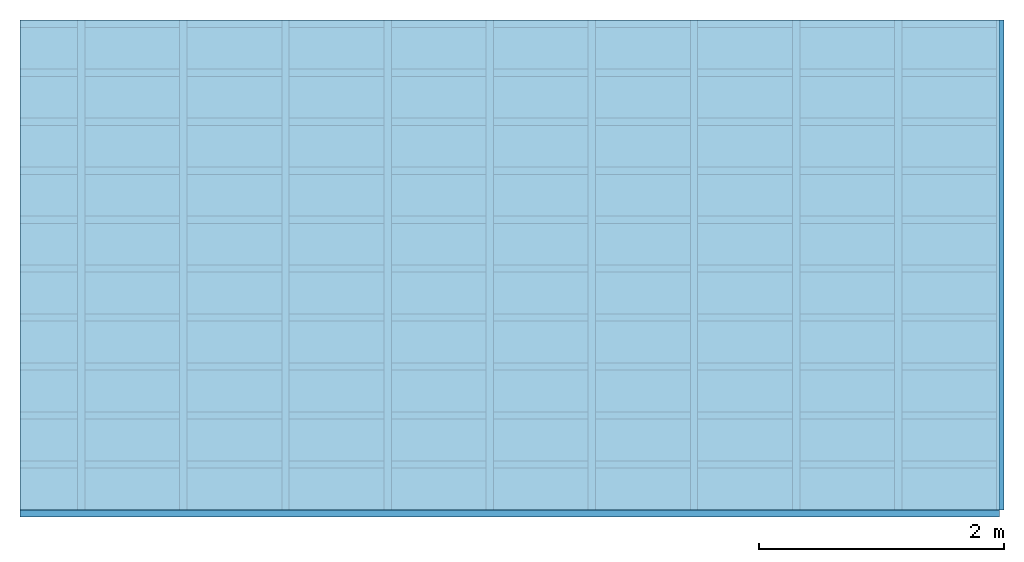
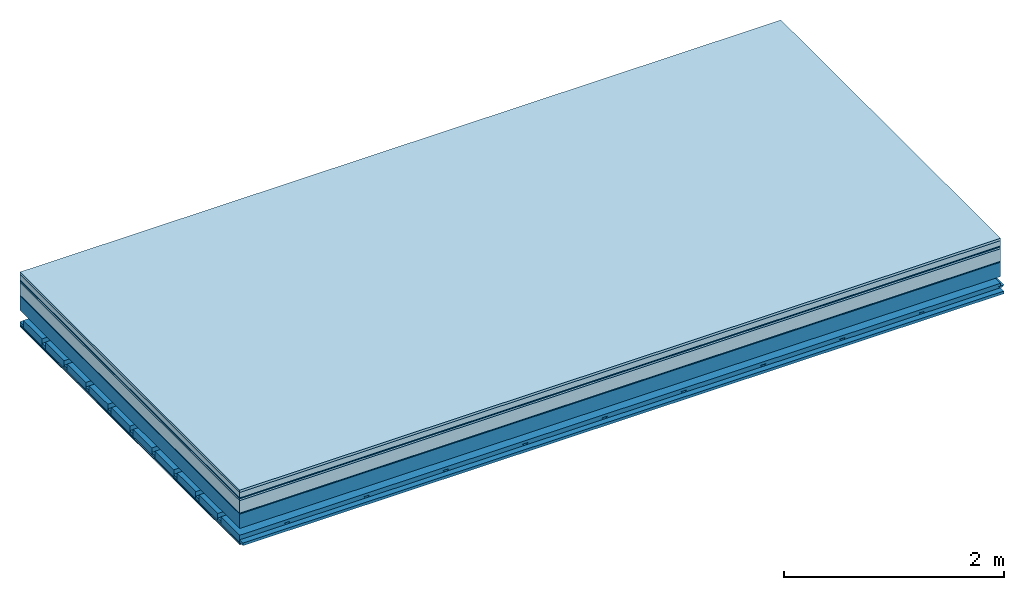
# One storey: 9 plates, 4 members, 1 element without a shape of its own.
"""IFC4 building model written with IfcOpenShell, lengths in metres."""

from ifc_helpers import new_model, si_unit, derived_unit, direction, frame, frame_2d, origin, origin_with_axes, place, context, project, spatial, polyline, rectangle, outline, extrude, material, layer, layer_set, type_object, element, aggregate, save


model = new_model("IFC4")

# Units and contexts
plan_context = context("Plan", 3, precision=1e-05, world=origin(), true_north=direction((0.0, 1.0)))
model_context = context("Model", 3, precision=1e-05, world=origin(), true_north=direction((0.0, 1.0)))
ifc_project = project(units=[si_unit("LENGTHUNIT", "METRE"), derived_unit("SOUNDPRESSUREUNIT", [(si_unit("PRESSUREUNIT", "PASCAL", prefix="MICRO"), 0)]), si_unit("ENERGYUNIT", "JOULE", prefix="MEGA"), si_unit("MASSUNIT", "GRAM", prefix="KILO"), derived_unit("THERMALTRANSMITTANCEUNIT", [(si_unit("POWERUNIT", "WATT"), 1), (si_unit("AREAUNIT", "SQUARE_METRE"), -1), (si_unit("THERMODYNAMICTEMPERATUREUNIT", "KELVIN"), -1)]), derived_unit("AREADENSITYUNIT", [(si_unit("MASSUNIT", "GRAM", prefix="KILO"), 1), (si_unit("AREAUNIT", "SQUARE_METRE"), -1)]), derived_unit("USERDEFINED", [(si_unit("ENERGYUNIT", "JOULE", prefix="MEGA"), 1), (si_unit("AREAUNIT", "SQUARE_METRE"), -1)])], contexts=[plan_context, model_context])

# Site, building, storey
site = spatial("IfcSite", under=ifc_project)
building_placement = place(None, origin())
building = spatial("IfcBuilding", under=site, at=building_placement)
storey_placement = place(building_placement, origin())
storey = spatial("IfcBuildingStorey", under=building, at=storey_placement)

# Slab, members, plates
ifc_material_1 = material(Category="07.009")
ifc_layer_1 = layer(ifc_material_1, 0.026, Name="Use and protection layer 3")
ifc_material_2 = material(Category="07.011")
ifc_layer_2 = layer(ifc_material_2, 0.06, Name="Use and protection layer 2")
ifc_material_3 = material(Name="Protective layer + Fire protection cover RF1", Category="09.007")
ifc_layer_3 = layer(ifc_material_3, 0.01, Name="Use and protection layer 1")
ifc_material_4 = material(Name="Bituminous", Category="09.003")
ifc_layer_4 = layer(ifc_material_4, 0.02, Name="Seal")
ifc_material_5 = material(Name="Mineral wool", Category="10.008")
ifc_layer_5 = layer(ifc_material_5, 0.14, Name="Exterior insulation layer 1")
ifc_material_6 = material(Name="Vapor-permeable barrier", Category="09.006")
ifc_layer_6 = layer(ifc_material_6, 0.01, Name="layer / temporary roof")
ifc_material_7 = material(Name="no composite action")
ifc_layer_7 = layer(ifc_material_7, 0.0, Name="Bond")
ifc_layer_8 = layer(None, 0.16, Name="Support")
ifc_layer_9 = layer(ifc_material_7, 0.0, Name="Bond")
ifc_layer_10 = layer(None, 0.125, Name="Coupling")
ifc_layer_11 = layer(None, 0.03, Name="Battens / profiles")
ifc_material_8 = material(Name="Plasterboard type A", Category="03.008")
ifc_layer_12 = layer(ifc_material_8, 0.0125, Name="Covering below 1st layer")
ifc_layer_13 = layer(ifc_material_8, 0.0125, Name="Covering below 2nd layer")
ifc_material_9 = material(Category="04.001")
ifc_layer_14 = layer(ifc_material_9, 0.003, Name="Surface below")
ifc_layer_set = layer_set([ifc_layer_1, ifc_layer_2, ifc_layer_3, ifc_layer_4, ifc_layer_5, ifc_layer_6, ifc_layer_7, ifc_layer_8, ifc_layer_9, ifc_layer_10, ifc_layer_11, ifc_layer_12, ifc_layer_13, ifc_layer_14])
slab_type = type_object("IfcSlabType", Name="F0068", PredefinedType="NOTDEFINED", material=ifc_layer_set)
slab_placement = place(None, frame((0.0, 0.0, 0.0), z_axis=(0.0, 0.0, -1.0), x_axis=(1.0, 0.0, 0.0)))
slab = element("IfcSlab", 1, at=slab_placement, inside=storey, type_object=slab_type, material=ifc_layer_set, Name="Slab #1")
ifc_material_10 = material(Name="Solid timber panel")
member_1_placement = place(slab_placement, origin())
member_1 = element("IfcMember", 2, at=member_1_placement, material=ifc_material_10, Name="Support", context=plan_context, shape_type="SweptSolid", body=[
    extrude(rectangle(XDim=1.0, YDim=0.16, at=frame_2d((0.5, 0.08), x_axis=(1.0, 0.0))), frame((0.0, 4.0, 0.266), z_axis=(0.0, -1.0, 0.0), x_axis=(1.0, 0.0, 0.0)), (0.0, 0.0, 1.0), 4.0),
    extrude(rectangle(XDim=1.0, YDim=0.16, at=frame_2d((0.5, 0.08), x_axis=(1.0, 0.0))), frame((1.0, 4.0, 0.266), z_axis=(0.0, -1.0, 0.0), x_axis=(1.0, 0.0, 0.0)), (0.0, 0.0, 1.0), 4.0),
    extrude(rectangle(XDim=1.0, YDim=0.16, at=frame_2d((0.5, 0.08), x_axis=(1.0, 0.0))), frame((2.0, 4.0, 0.266), z_axis=(0.0, -1.0, 0.0), x_axis=(1.0, 0.0, 0.0)), (0.0, 0.0, 1.0), 4.0),
    extrude(rectangle(XDim=1.0, YDim=0.16, at=frame_2d((0.5, 0.08), x_axis=(1.0, 0.0))), frame((3.0, 4.0, 0.266), z_axis=(0.0, -1.0, 0.0), x_axis=(1.0, 0.0, 0.0)), (0.0, 0.0, 1.0), 4.0),
    extrude(rectangle(XDim=1.0, YDim=0.16, at=frame_2d((0.5, 0.08), x_axis=(1.0, 0.0))), frame((4.0, 4.0, 0.266), z_axis=(0.0, -1.0, 0.0), x_axis=(1.0, 0.0, 0.0)), (0.0, 0.0, 1.0), 4.0),
    extrude(rectangle(XDim=1.0, YDim=0.16, at=frame_2d((0.5, 0.08), x_axis=(1.0, 0.0))), frame((5.0, 4.0, 0.266), z_axis=(0.0, -1.0, 0.0), x_axis=(1.0, 0.0, 0.0)), (0.0, 0.0, 1.0), 4.0),
    extrude(rectangle(XDim=1.0, YDim=0.16, at=frame_2d((0.5, 0.08), x_axis=(1.0, 0.0))), frame((6.0, 4.0, 0.266), z_axis=(0.0, -1.0, 0.0), x_axis=(1.0, 0.0, 0.0)), (0.0, 0.0, 1.0), 4.0),
    extrude(rectangle(XDim=1.0, YDim=0.16, at=frame_2d((0.5, 0.08), x_axis=(1.0, 0.0))), frame((7.0, 4.0, 0.266), z_axis=(0.0, -1.0, 0.0), x_axis=(1.0, 0.0, 0.0)), (0.0, 0.0, 1.0), 4.0),
])
ifc_material_11 = material()
member_2_placement = place(slab_placement, origin())
member_2 = element("IfcMember", 3, at=member_2_placement, material=ifc_material_11, Name="Coupling", context=plan_context, shape_type="SweptSolid", body=[
    extrude(outline(polyline([(0.0, 0.0), (0.06, 0.0), (0.04, 0.02), (0.02, 0.02), (0.0, 0.0)])), frame((0.47, 4.0, 0.531), z_axis=(0.0, -1.0, 0.0), x_axis=(1.0, 0.0, 0.0)), (0.0, 0.0, 1.0), 4.0),
    extrude(outline(polyline([(0.0, 0.0), (0.06, 0.0), (0.04, 0.02), (0.02, 0.02), (0.0, 0.0)])), frame((1.304, 4.0, 0.531), z_axis=(0.0, -1.0, 0.0), x_axis=(1.0, 0.0, 0.0)), (0.0, 0.0, 1.0), 4.0),
    extrude(outline(polyline([(0.0, 0.0), (0.06, 0.0), (0.04, 0.02), (0.02, 0.02), (0.0, 0.0)])), frame((2.138, 4.0, 0.531), z_axis=(0.0, -1.0, 0.0), x_axis=(1.0, 0.0, 0.0)), (0.0, 0.0, 1.0), 4.0),
    extrude(outline(polyline([(0.0, 0.0), (0.06, 0.0), (0.04, 0.02), (0.02, 0.02), (0.0, 0.0)])), frame((2.972, 4.0, 0.531), z_axis=(0.0, -1.0, 0.0), x_axis=(1.0, 0.0, 0.0)), (0.0, 0.0, 1.0), 4.0),
    extrude(outline(polyline([(0.0, 0.0), (0.06, 0.0), (0.04, 0.02), (0.02, 0.02), (0.0, 0.0)])), frame((3.806, 4.0, 0.531), z_axis=(0.0, -1.0, 0.0), x_axis=(1.0, 0.0, 0.0)), (0.0, 0.0, 1.0), 4.0),
    extrude(outline(polyline([(0.0, 0.0), (0.06, 0.0), (0.04, 0.02), (0.02, 0.02), (0.0, 0.0)])), frame((4.64, 4.0, 0.531), z_axis=(0.0, -1.0, 0.0), x_axis=(1.0, 0.0, 0.0)), (0.0, 0.0, 1.0), 4.0),
    extrude(outline(polyline([(0.0, 0.0), (0.06, 0.0), (0.04, 0.02), (0.02, 0.02), (0.0, 0.0)])), frame((5.474, 4.0, 0.531), z_axis=(0.0, -1.0, 0.0), x_axis=(1.0, 0.0, 0.0)), (0.0, 0.0, 1.0), 4.0),
    extrude(outline(polyline([(0.0, 0.0), (0.06, 0.0), (0.04, 0.02), (0.02, 0.02), (0.0, 0.0)])), frame((6.308, 4.0, 0.531), z_axis=(0.0, -1.0, 0.0), x_axis=(1.0, 0.0, 0.0)), (0.0, 0.0, 1.0), 4.0),
    extrude(outline(polyline([(0.0, 0.0), (0.06, 0.0), (0.04, 0.02), (0.02, 0.02), (0.0, 0.0)])), frame((7.142, 4.0, 0.531), z_axis=(0.0, -1.0, 0.0), x_axis=(1.0, 0.0, 0.0)), (0.0, 0.0, 1.0), 4.0),
    extrude(outline(polyline([(0.0, 0.0), (0.06, 0.0), (0.04, 0.02), (0.02, 0.02), (0.0, 0.0)])), frame((7.976, 4.0, 0.531), z_axis=(0.0, -1.0, 0.0), x_axis=(1.0, 0.0, 0.0)), (0.0, 0.0, 1.0), 4.0),
])
member_3_placement = place(slab_placement, origin())
member_3 = element("IfcMember", 4, at=member_3_placement, material=ifc_material_11, Name="Battens / profiles", context=plan_context, shape_type="SweptSolid", body=[
    extrude(rectangle(XDim=0.06, YDim=0.03, at=frame_2d((0.03, 0.015), x_axis=(1.0, 0.0))), frame((0.0, 0.0, 0.551), z_axis=(1.0, 0.0, 0.0), x_axis=(0.0, 1.0, 0.0)), (0.0, 0.0, 1.0), 8.0),
    extrude(rectangle(XDim=0.06, YDim=0.03, at=frame_2d((0.03, 0.015), x_axis=(1.0, 0.0))), frame((0.0, 0.4, 0.551), z_axis=(1.0, 0.0, 0.0), x_axis=(0.0, 1.0, 0.0)), (0.0, 0.0, 1.0), 8.0),
    extrude(rectangle(XDim=0.06, YDim=0.03, at=frame_2d((0.03, 0.015), x_axis=(1.0, 0.0))), frame((0.0, 0.8, 0.551), z_axis=(1.0, 0.0, 0.0), x_axis=(0.0, 1.0, 0.0)), (0.0, 0.0, 1.0), 8.0),
    extrude(rectangle(XDim=0.06, YDim=0.03, at=frame_2d((0.03, 0.015), x_axis=(1.0, 0.0))), frame((0.0, 1.2, 0.551), z_axis=(1.0, 0.0, 0.0), x_axis=(0.0, 1.0, 0.0)), (0.0, 0.0, 1.0), 8.0),
    extrude(rectangle(XDim=0.06, YDim=0.03, at=frame_2d((0.03, 0.015), x_axis=(1.0, 0.0))), frame((0.0, 1.6, 0.551), z_axis=(1.0, 0.0, 0.0), x_axis=(0.0, 1.0, 0.0)), (0.0, 0.0, 1.0), 8.0),
    extrude(rectangle(XDim=0.06, YDim=0.03, at=frame_2d((0.03, 0.015), x_axis=(1.0, 0.0))), frame((0.0, 2.0, 0.551), z_axis=(1.0, 0.0, 0.0), x_axis=(0.0, 1.0, 0.0)), (0.0, 0.0, 1.0), 8.0),
    extrude(rectangle(XDim=0.06, YDim=0.03, at=frame_2d((0.03, 0.015), x_axis=(1.0, 0.0))), frame((0.0, 2.4, 0.551), z_axis=(1.0, 0.0, 0.0), x_axis=(0.0, 1.0, 0.0)), (0.0, 0.0, 1.0), 8.0),
    extrude(rectangle(XDim=0.06, YDim=0.03, at=frame_2d((0.03, 0.015), x_axis=(1.0, 0.0))), frame((0.0, 2.8, 0.551), z_axis=(1.0, 0.0, 0.0), x_axis=(0.0, 1.0, 0.0)), (0.0, 0.0, 1.0), 8.0),
    extrude(rectangle(XDim=0.06, YDim=0.03, at=frame_2d((0.03, 0.015), x_axis=(1.0, 0.0))), frame((0.0, 3.2, 0.551), z_axis=(1.0, 0.0, 0.0), x_axis=(0.0, 1.0, 0.0)), (0.0, 0.0, 1.0), 8.0),
    extrude(rectangle(XDim=0.06, YDim=0.03, at=frame_2d((0.03, 0.015), x_axis=(1.0, 0.0))), frame((0.0, 3.6, 0.551), z_axis=(1.0, 0.0, 0.0), x_axis=(0.0, 1.0, 0.0)), (0.0, 0.0, 1.0), 8.0),
    extrude(rectangle(XDim=0.06, YDim=0.03, at=frame_2d((0.03, 0.015), x_axis=(1.0, 0.0))), frame((0.0, 4.0, 0.551), z_axis=(1.0, 0.0, 0.0), x_axis=(0.0, 1.0, 0.0)), (0.0, 0.0, 1.0), 8.0),
])
ifc_material_12 = material()
member_4_placement = place(slab_placement, origin())
member_4 = element("IfcMember", 5, at=member_4_placement, material=ifc_material_12, Name="Cavity", context=plan_context, shape_type="SweptSolid", body=[
    extrude(rectangle(XDim=0.34, YDim=0.08, at=frame_2d((0.17, 0.04), x_axis=(1.0, 0.0))), frame((0.0, 0.06, 0.501), z_axis=(1.0, 0.0, 0.0), x_axis=(0.0, 1.0, 0.0)), (0.0, 0.0, 1.0), 8.0),
    extrude(rectangle(XDim=0.34, YDim=0.08, at=frame_2d((0.17, 0.04), x_axis=(1.0, 0.0))), frame((0.0, 0.46, 0.501), z_axis=(1.0, 0.0, 0.0), x_axis=(0.0, 1.0, 0.0)), (0.0, 0.0, 1.0), 8.0),
    extrude(rectangle(XDim=0.34, YDim=0.08, at=frame_2d((0.17, 0.04), x_axis=(1.0, 0.0))), frame((0.0, 0.86, 0.501), z_axis=(1.0, 0.0, 0.0), x_axis=(0.0, 1.0, 0.0)), (0.0, 0.0, 1.0), 8.0),
    extrude(rectangle(XDim=0.34, YDim=0.08, at=frame_2d((0.17, 0.04), x_axis=(1.0, 0.0))), frame((0.0, 1.26, 0.501), z_axis=(1.0, 0.0, 0.0), x_axis=(0.0, 1.0, 0.0)), (0.0, 0.0, 1.0), 8.0),
    extrude(rectangle(XDim=0.34, YDim=0.08, at=frame_2d((0.17, 0.04), x_axis=(1.0, 0.0))), frame((0.0, 1.66, 0.501), z_axis=(1.0, 0.0, 0.0), x_axis=(0.0, 1.0, 0.0)), (0.0, 0.0, 1.0), 8.0),
    extrude(rectangle(XDim=0.34, YDim=0.08, at=frame_2d((0.17, 0.04), x_axis=(1.0, 0.0))), frame((0.0, 2.06, 0.501), z_axis=(1.0, 0.0, 0.0), x_axis=(0.0, 1.0, 0.0)), (0.0, 0.0, 1.0), 8.0),
    extrude(rectangle(XDim=0.34, YDim=0.08, at=frame_2d((0.17, 0.04), x_axis=(1.0, 0.0))), frame((0.0, 2.46, 0.501), z_axis=(1.0, 0.0, 0.0), x_axis=(0.0, 1.0, 0.0)), (0.0, 0.0, 1.0), 8.0),
    extrude(rectangle(XDim=0.34, YDim=0.08, at=frame_2d((0.17, 0.04), x_axis=(1.0, 0.0))), frame((0.0, 2.86, 0.501), z_axis=(1.0, 0.0, 0.0), x_axis=(0.0, 1.0, 0.0)), (0.0, 0.0, 1.0), 8.0),
    extrude(rectangle(XDim=0.34, YDim=0.08, at=frame_2d((0.17, 0.04), x_axis=(1.0, 0.0))), frame((0.0, 3.26, 0.501), z_axis=(1.0, 0.0, 0.0), x_axis=(0.0, 1.0, 0.0)), (0.0, 0.0, 1.0), 8.0),
    extrude(rectangle(XDim=0.34, YDim=0.08, at=frame_2d((0.17, 0.04), x_axis=(1.0, 0.0))), frame((0.0, 3.66, 0.501), z_axis=(1.0, 0.0, 0.0), x_axis=(0.0, 1.0, 0.0)), (0.0, 0.0, 1.0), 8.0),
])
plate_1_placement = place(slab_placement, origin())
plate_1 = element("IfcPlate", 6, at=plate_1_placement, material=ifc_material_1, Name="Use and protection layer 3", context=plan_context, shape_type="SweptSolid", body=[
    extrude(rectangle(XDim=8.0, YDim=4.0, at=frame_2d((4.0, 2.0), x_axis=(1.0, 0.0))), origin_with_axes(), (0.0, 0.0, 1.0), 0.026),
])
plate_2_placement = place(slab_placement, origin())
plate_2 = element("IfcPlate", 7, at=plate_2_placement, material=ifc_material_2, Name="Use and protection layer 2", context=plan_context, shape_type="SweptSolid", body=[
    extrude(rectangle(XDim=8.0, YDim=4.0, at=frame_2d((4.0, 2.0), x_axis=(1.0, 0.0))), frame((0.0, 0.0, 0.026), z_axis=(0.0, 0.0, 1.0), x_axis=(1.0, 0.0, 0.0)), (0.0, 0.0, 1.0), 0.06),
])
plate_3_placement = place(slab_placement, origin())
plate_3 = element("IfcPlate", 8, at=plate_3_placement, material=ifc_material_3, Name="Use and protection layer 1", context=plan_context, shape_type="SweptSolid", body=[
    extrude(rectangle(XDim=8.0, YDim=4.0, at=frame_2d((4.0, 2.0), x_axis=(1.0, 0.0))), frame((0.0, 0.0, 0.086), z_axis=(0.0, 0.0, 1.0), x_axis=(1.0, 0.0, 0.0)), (0.0, 0.0, 1.0), 0.01),
])
plate_4_placement = place(slab_placement, origin())
plate_4 = element("IfcPlate", 9, at=plate_4_placement, material=ifc_material_4, Name="Seal", context=plan_context, shape_type="SweptSolid", body=[
    extrude(rectangle(XDim=8.0, YDim=4.0, at=frame_2d((4.0, 2.0), x_axis=(1.0, 0.0))), frame((0.0, 0.0, 0.096), z_axis=(0.0, 0.0, 1.0), x_axis=(1.0, 0.0, 0.0)), (0.0, 0.0, 1.0), 0.02),
])
plate_5_placement = place(slab_placement, origin())
plate_5 = element("IfcPlate", 10, at=plate_5_placement, material=ifc_material_5, Name="Exterior insulation layer 1", context=plan_context, shape_type="SweptSolid", body=[
    extrude(rectangle(XDim=8.0, YDim=4.0, at=frame_2d((4.0, 2.0), x_axis=(1.0, 0.0))), frame((0.0, 0.0, 0.116), z_axis=(0.0, 0.0, 1.0), x_axis=(1.0, 0.0, 0.0)), (0.0, 0.0, 1.0), 0.14),
])
plate_6_placement = place(slab_placement, origin())
plate_6 = element("IfcPlate", 11, at=plate_6_placement, material=ifc_material_6, Name="layer / temporary roof", context=plan_context, shape_type="SweptSolid", body=[
    extrude(rectangle(XDim=8.0, YDim=4.0, at=frame_2d((4.0, 2.0), x_axis=(1.0, 0.0))), frame((0.0, 0.0, 0.256), z_axis=(0.0, 0.0, 1.0), x_axis=(1.0, 0.0, 0.0)), (0.0, 0.0, 1.0), 0.01),
])
plate_7_placement = place(slab_placement, origin())
plate_7 = element("IfcPlate", 12, at=plate_7_placement, material=ifc_material_8, Name="Covering below 1st layer", context=plan_context, shape_type="SweptSolid", body=[
    extrude(rectangle(XDim=8.0, YDim=4.0, at=frame_2d((4.0, 2.0), x_axis=(1.0, 0.0))), frame((0.0, 0.0, 0.581), z_axis=(0.0, 0.0, 1.0), x_axis=(1.0, 0.0, 0.0)), (0.0, 0.0, 1.0), 0.0125),
])
plate_8_placement = place(slab_placement, origin())
plate_8 = element("IfcPlate", 13, at=plate_8_placement, material=ifc_material_8, Name="Covering below 2nd layer", context=plan_context, shape_type="SweptSolid", body=[
    extrude(rectangle(XDim=8.0, YDim=4.0, at=frame_2d((4.0, 2.0), x_axis=(1.0, 0.0))), frame((0.0, 0.0, 0.5935), z_axis=(0.0, 0.0, 1.0), x_axis=(1.0, 0.0, 0.0)), (0.0, 0.0, 1.0), 0.0125),
])
plate_9_placement = place(slab_placement, origin())
plate_9 = element("IfcPlate", 14, at=plate_9_placement, material=ifc_material_9, Name="Surface below", context=plan_context, shape_type="SweptSolid", body=[
    extrude(rectangle(XDim=8.0, YDim=4.0, at=frame_2d((4.0, 2.0), x_axis=(1.0, 0.0))), frame((0.0, 0.0, 0.606), z_axis=(0.0, 0.0, 1.0), x_axis=(1.0, 0.0, 0.0)), (0.0, 0.0, 1.0), 0.003),
])
aggregate(slab, [plate_1, plate_2, plate_3, plate_4, plate_5, plate_6, member_1, member_2, member_3, member_4, plate_7, plate_8, plate_9])

save(model, "model.ifc")
